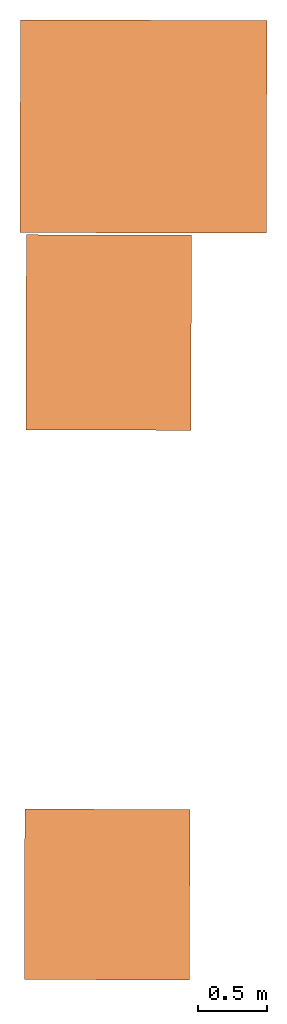
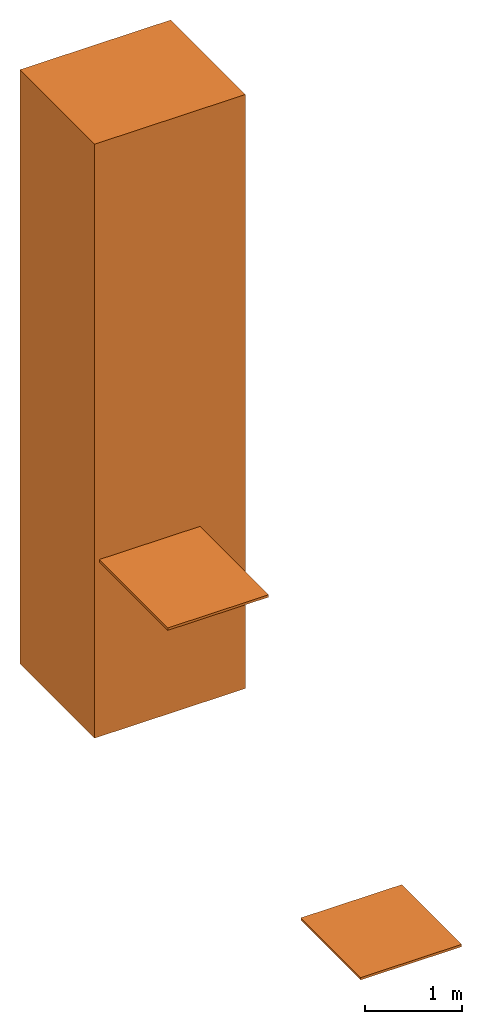
# One storey: 3 proxies.
"""IFC4 building model written with IfcOpenShell, lengths in metres."""

from ifc_helpers import new_model, entity, si_unit, converted_unit, derived_unit, direction, frame, origin, place, context, subcontext, project, spatial, indexed_curve, outline, extrude, source, transform, mapped, material, type_object, type_shapes, element, save


model = new_model("IFC4")

# Units and contexts
model_context = context("Model", 3, precision=1e-05, world=origin(), true_north=direction((6.123233995736766e-17, 1.0)))
body_context = subcontext(model_context, "Body", "Model", "MODEL_VIEW")
ifc_project = project(units=[si_unit("LENGTHUNIT", "METRE"), si_unit("AREAUNIT", "SQUARE_METRE"), si_unit("VOLUMEUNIT", "CUBIC_METRE"), converted_unit("PLANEANGLEUNIT", "DEGREE", entity("IfcPlaneAngleMeasure", 0.017453292519943278), si_unit("PLANEANGLEUNIT", "RADIAN"), dimensions=[0, 0, 0, 0, 0, 0, 0]), derived_unit("THERMALTRANSMITTANCEUNIT", [(si_unit("MASSUNIT", "GRAM", prefix="KILO"), 1), (si_unit("THERMODYNAMICTEMPERATUREUNIT", "KELVIN"), -1), (si_unit("TIMEUNIT", "SECOND"), -3)])], contexts=[model_context])

# Site, building, storey
site_placement = place(None, origin())
site = spatial("IfcSite", under=ifc_project, at=site_placement, CompositionType="ELEMENT")
building_placement = place(site_placement, origin())
building = spatial("IfcBuilding", under=site, at=building_placement, CompositionType="ELEMENT")
storey_placement = place(building_placement, frame((0.0, 0.0, -4.819999999999999)))
storey = spatial("IfcBuildingStorey", under=building, at=storey_placement, Name="- 4.82 m", CompositionType="ELEMENT", Elevation=-4.819999999999999)

# Proxies
ifc_material_1 = material(Name="Acciaio", Category="Metallo")
building_element_proxy_type_1 = type_object("IfcBuildingElementProxyType", Name="Massa 2:Massa 2", PredefinedType="NOTDEFINED", material=ifc_material_1)
shared_shape_1 = source(origin(), body_context, "Body", "SweptSolid", [
    extrude(outline(indexed_curve([(-3.750091479636352, -0.7749999999772045), (3.750091479636352, -0.774999999977198), (3.7500914796363527, 0.7749999999772024), (-3.750091479636352, 0.7749999999771958), (-3.750091479636352, -0.7749999999772045)], self_intersect=False)), frame((0.4172521413354232, 13.044910425024618, -1.0699085203636476), z_axis=(0.9999981490020482, -0.001924056256304185, 0.0), x_axis=(0.0, 0.0, 1.0)), (0.0, 0.0, 1.0), 1.7969999999950221),
])
type_shapes(building_element_proxy_type_1, [shared_shape_1])
proxy_1_placement = place(storey_placement, frame((0.0, 0.0, 4.819999999999999)))
element("IfcBuildingElementProxy", 1, at=proxy_1_placement, inside=storey, type_object=building_element_proxy_type_1, material=ifc_material_1, Name="Massa 2:Massa 2", ObjectType="Massa 2:Massa 2", PredefinedType="NOTDEFINED", context=body_context, shape_type="MappedRepresentation", body=[
    mapped(shared_shape_1, transform((0.0, 0.0, 0.0), scale=1.0)),
])
ifc_material_2 = material()
building_element_proxy_type_2 = type_object("IfcBuildingElementProxyType", Name="Pedata:Pedata", PredefinedType="NOTDEFINED", material=ifc_material_2)
shared_shape_2 = source(origin(), body_context, "Body", "SweptSolid", [
    extrude(outline(indexed_curve([(-0.601928523626804, -0.6215000000000006), (0.601928523626804, -0.6215000000000006), (0.601928523626804, 0.6215000000000006), (-0.601928523626804, 0.6215000000000006), (-0.601928523626804, -0.6215000000000006)], self_intersect=False)), frame((0.0, 0.0015000000000075099, -0.029999999999995308), z_axis=(0.0, 0.0, 1.0), x_axis=(-1.0, 0.0, 0.0)), (0.0, 0.0, 1.0), 0.002999999999995308),
    extrude(outline(indexed_curve([(-0.6214999999999954, -0.6019285236267988), (0.6214999999999954, -0.6019285236267988), (0.6214999999999954, 0.6019285236267988), (-0.6214999999999954, 0.6019285236267988), (-0.6214999999999954, -0.6019285236267988)], self_intersect=False), holes=[indexed_curve([(0.6184999999999949, -0.5989285236267983), (-0.6184999999999949, -0.5989285236267983), (-0.6184999999999949, 0.5989285236267983), (0.6184999999999949, 0.5989285236267983), (0.6184999999999949, -0.5989285236267983)], self_intersect=False)]), frame((0.0, 0.0015000000000075099, -0.026999999999995302), z_axis=(0.0, 0.0, 1.0), x_axis=(0.0, 1.0, 0.0)), (0.0, 0.0, 1.0), 0.026999999999995302),
    extrude(outline(indexed_curve([(-0.5989285236268005, -0.6184999999999984), (0.5989285236268005, -0.6184999999999984), (0.5989285236268005, 0.6184999999999984), (-0.5989285236268005, 0.6184999999999984), (-0.5989285236268005, -0.6184999999999984)], self_intersect=False)), frame((0.0, 0.0015000000000081866, -0.027), z_axis=(0.0, 0.0, 1.0), x_axis=(-1.0, 0.0, 0.0)), (0.0, 0.0, 1.0), 0.027),
])
type_shapes(building_element_proxy_type_2, [shared_shape_2])
proxy_2_placement = place(storey_placement, frame((1.0512280179093276, 7.442589931325571, 0.2681754393991123), z_axis=(0.0, 0.0, 1.0), x_axis=(0.9999964429594089, -0.0026672211249992436, 0.0)))
element("IfcBuildingElementProxy", 2, at=proxy_2_placement, inside=storey, type_object=building_element_proxy_type_2, material=ifc_material_2, Name="Pedata:Pedata", ObjectType="Pedata:Pedata", PredefinedType="NOTDEFINED", context=body_context, shape_type="MappedRepresentation", body=[
    mapped(shared_shape_2, transform((0.0, 0.0, 0.0), scale=1.0)),
])
building_element_proxy_type_3 = type_object("IfcBuildingElementProxyType", Name="Pedata:Pedata", PredefinedType="NOTDEFINED", material=ifc_material_2)
shared_shape_3 = source(origin(), body_context, "Body", "SweptSolid", [
    extrude(outline(indexed_curve([(-0.6019285236267987, -0.7115000000000006), (0.6019285236267988, -0.7115000000000007), (0.6019285236267987, 0.7115000000000007), (-0.6019285236267988, 0.7115000000000008), (-0.6019285236267987, -0.7115000000000006)], self_intersect=False)), frame((0.0, 0.001500000000007476, -0.029999999999995308), z_axis=(0.0, 0.0, 1.0), x_axis=(-1.0, 0.0, 0.0)), (0.0, 0.0, 1.0), 0.002999999999995308),
    extrude(outline(indexed_curve([(-0.7114999999999956, -0.6019285236267936), (0.7114999999999956, -0.6019285236267936), (0.7114999999999956, 0.6019285236267936), (-0.7114999999999956, 0.6019285236267936), (-0.7114999999999956, -0.6019285236267936)], self_intersect=False), holes=[indexed_curve([(0.7084999999999949, -0.598928523626793), (-0.708499999999995, -0.598928523626793), (-0.708499999999995, 0.598928523626793), (0.708499999999995, 0.598928523626793), (0.7084999999999949, -0.598928523626793)], self_intersect=False)]), frame((0.0, 0.0015000000000075099, -0.026999999999995302), z_axis=(0.0, 0.0, 1.0), x_axis=(0.0, 1.0, 0.0)), (0.0, 0.0, 1.0), 0.026999999999995302),
    extrude(outline(indexed_curve([(-0.598928523626795, -0.7084999999999982), (0.5989285236267952, -0.7084999999999984), (0.598928523626795, 0.7084999999999984), (-0.5989285236267952, 0.7084999999999986), (-0.598928523626795, -0.7084999999999982)], self_intersect=False)), frame((0.0, 0.001500000000008288, -0.027), z_axis=(0.0, 0.0, 1.0), x_axis=(-1.0, 0.0, 0.0)), (0.0, 0.0, 1.0), 0.027),
])
type_shapes(building_element_proxy_type_3, [shared_shape_3])
proxy_3_placement = place(storey_placement, frame((1.062156450042246, 11.53988548646528, 2.249090470553896), z_axis=(0.0, 0.0, 1.0), x_axis=(0.9999964429594089, -0.0026672211249992436, 0.0)))
element("IfcBuildingElementProxy", 3, at=proxy_3_placement, inside=storey, type_object=building_element_proxy_type_3, material=ifc_material_2, Name="Pedata:Pedata", ObjectType="Pedata:Pedata", PredefinedType="NOTDEFINED", context=body_context, shape_type="MappedRepresentation", body=[
    mapped(shared_shape_3, transform((0.0, 0.0, 0.0), scale=1.0)),
])

save(model, "model.ifc")
